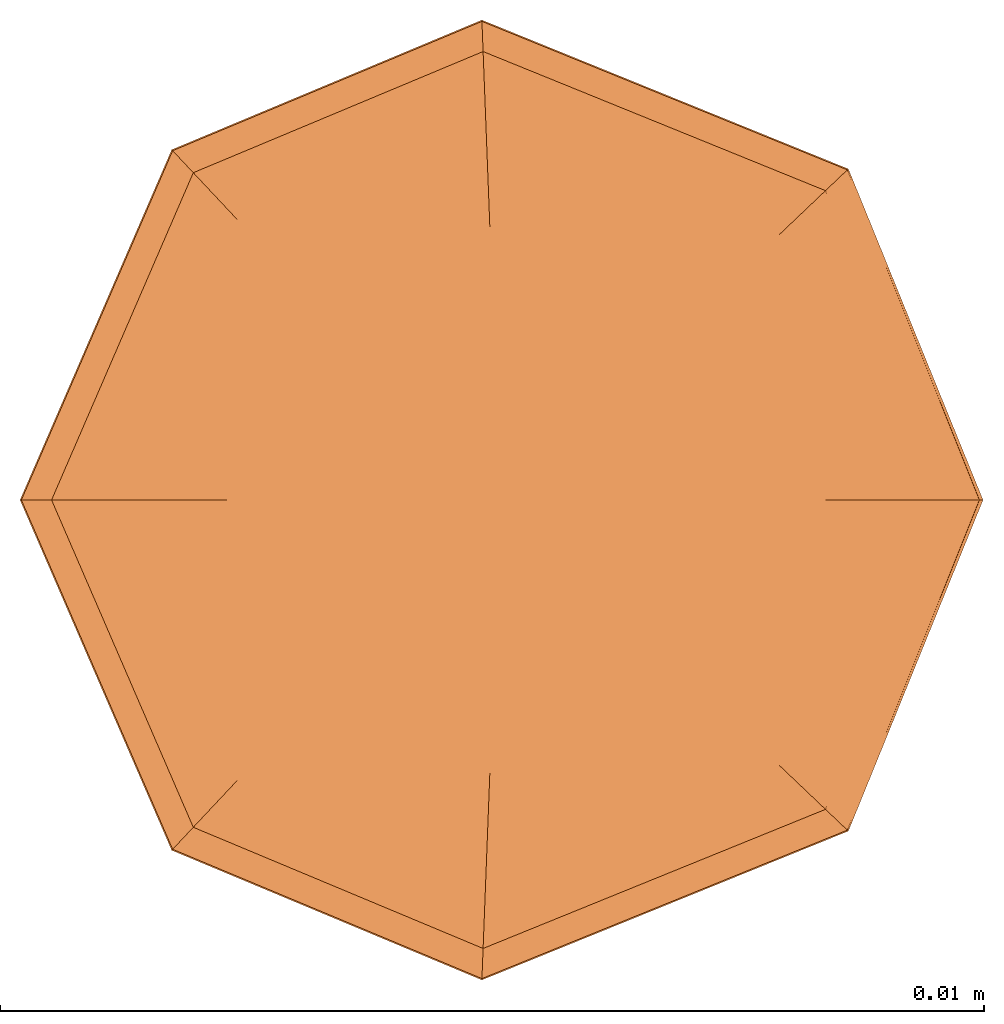
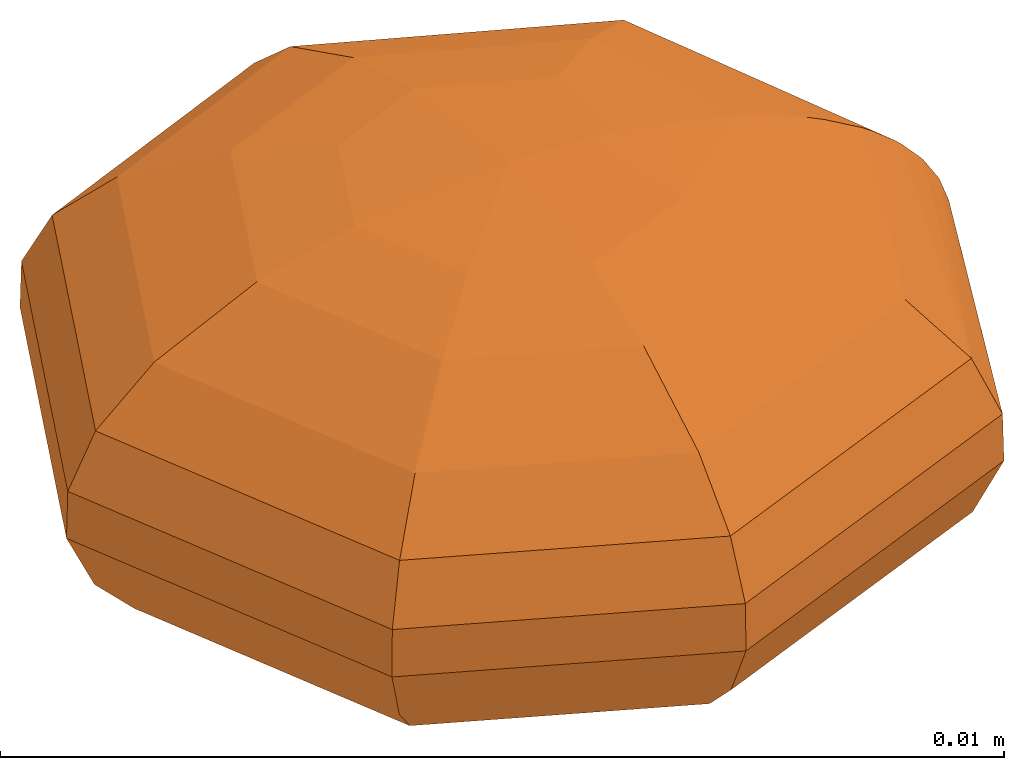
# One storey: 1 proxy.
"""IFC2X3 building model written with IfcOpenShell, lengths in metres."""

from ifc_helpers import new_model, entity, si_unit, converted_unit, direction, origin_with_axes, place, context, project, spatial, faceted_brep, element, save


model = new_model("IFC2X3")

# Units and contexts
model_context = context("Model", 3, precision=1e-05, world=origin_with_axes(), true_north=direction((0.0, 1.0, 0.0)))
ifc_project = project(units=[si_unit("LENGTHUNIT", "METRE"), si_unit("AREAUNIT", "SQUARE_METRE"), si_unit("VOLUMEUNIT", "CUBIC_METRE"), converted_unit("PLANEANGLEUNIT", "DEGREE", entity("IfcPlaneAngleMeasure", 0.017453292519943295), si_unit("PLANEANGLEUNIT", "RADIAN"), dimensions=[0, 0, 0, 0, 0, 0, 0])], contexts=[model_context])

# Site, building, storey
site = spatial("IfcSite", under=ifc_project, CompositionType="ELEMENT")
building = spatial("IfcBuilding", under=site, Name="Default Building", CompositionType="ELEMENT")
storey = spatial("IfcBuildingStorey", under=building, Name="Default Storey", CompositionType="ELEMENT")

# Proxy
proxy_placement = place(None, origin_with_axes())
element("IfcBuildingElementProxy", 1, at=proxy_placement, inside=storey, CompositionType="ELEMENT", context=model_context, shape_type="Brep", body=[
    faceted_brep([(-0.000152662271453074, 0.00396628215833403, 0.000247638885958941), (0.00288400588105378, 0.00274386681545339, -0.000196026131613179), (-0.00015310540430296, 0.0039777950874916, -0.000196026131613179), (0.0038979625190392, -9.55000817164605e-19, -0.000448856380194588), (0.00270157264392012, 0.00257029833950289, -0.000723718124612603), (-0.00254468377132875, 0.00271232097300763, 0.000736189419123744), (-0.000143044354009601, 0.00371640133320756, 0.000736189419123744), (-0.00271578146058632, 0.0028946901366087, 0.000247638885958941), (0.00287565870512634, 0.00273592524391204, 0.000247638885958941), (-0.00254468377132876, -0.00271232097300762, 0.000736189419123744), (-0.00396921905778001, 3.63396005958287e-18, 0.000247638885958941), (-0.00271578146058633, -0.00289469013660869, 0.000247638885958941), (-0.00371915320424972, 3.45968135853141e-18, 0.000736189419123744), (-0.00176506971101033, 1.69896230798885e-18, -0.00179475129999075), (-0.00120767927595444, 0.00128723807089298, -0.00179475129999075), (0.0, 0.0, -0.002), (-0.000129617050998011, -0.0033675497678369, -0.00107735880527708), (-0.0019942564412805, -0.00212563291053497, -0.00136972862057251), (-0.000112103172734707, -0.00291252586299263, -0.00136972862057251), (-0.00230581911775401, -0.00245772053231605, -0.00107735880527708), (-0.00272366456075797, 0.00290309255508159, -0.000196026131613179), (-0.00398074051187704, 3.63778251990386e-18, -0.000196026131613179), (-0.000143420432884163, 0.00372617214898348, -0.000723718124612603), (-0.00255137401657096, 0.00271945195434584, -0.000723718124612603), (-0.000152662271453083, -0.00396628215833403, 0.000247638885958941), (-0.00272366456075798, -0.00290309255508159, -0.000196026131613179), (-0.000153105404302969, -0.0039777950874916, -0.000196026131613179), (-0.000947249785860373, 0.00100965215788856, 0.00187638751083421), (0.0, 0.0, 0.002), (-5.32477690276527e-05, 0.00138341762018384, 0.00187638751083421), (-0.0019942564412805, 0.00212563291053497, -0.00136972862057251), (-0.0001121031727347, 0.00291252586299263, -0.00136972862057251), (-6.78872965773188e-05, 0.00176376370290624, -0.00179475129999075), (-8.71058835748227e-05, 0.00226307723984665, 0.00164855193818202), (-0.00154956782359426, 0.00165164935399334, 0.00164855193818202), (-6.7887296577323e-05, -0.00176376370290624, -0.00179475129999075), (-0.00120767927595444, -0.00128723807089297, -0.00179475129999075), (-0.00291468249110227, 2.76340206212976e-18, -0.00136972862057251), (0.00288400588105377, -0.00274386681545339, -0.000196026131613179), (0.00397541174692305, -9.73975877996147e-19, -0.000221416712572831), (0.00127877499471157, 0.0012166370032292, -0.00179475129999075), (0.00176506971101033, -4.32442079197532e-19, -0.00179475129999075), (0.00398074051187704, -9.75281425409875e-19, -0.00019602613161318), (0.004, -9.8e-19, -4.9e-19), (0.00399968870455559, -9.79923732616119e-19, 2.4951285790703e-05), (0.00100301409821479, 0.000954275827800281, 0.00187638751083421), (0.00203456677252254, -4.98468859268023e-19, 0.001721956594121), (0.00164079041917477, 0.00156106144299626, 0.00164855193818202), (0.00138444199471901, -3.39188288706157e-19, 0.00187638751083421), (0.00101768288308343, -2.49332306355439e-19, 0.00193418726791636), (0.000683750669828254, -1.67518914107922e-19, 0.00197056368975412), (-0.000143420432884172, -0.00372617214898348, -0.000723718124612603), (0.00270157264392011, -0.00257029833950289, -0.000723718124612603), (-0.00372893125498833, 3.46745470559538e-18, -0.000723718124612603), (-0.00255137401657097, -0.00271945195434584, -0.000723718124612603), (0.00244156200145224, 0.0023229220847528, -0.00107735880527708), (-0.000129617050998003, 0.0033675497678369, -0.00107735880527708), (-0.00226475297294545, 2.16719591337292e-18, 0.00164855193818202), (-0.00218281415605064, 0.00232661232108326, 0.00120646150658946), (-0.002305819117754, 0.00245772053231605, -0.00107735880527708), (-0.00319026684345864, 3.009695545214e-18, 0.00120646150658946), (-0.00337004332594816, 3.16709775165534e-18, -0.00107735880527708), (0.00211165772314552, -0.00200904845243165, -0.00136972862057251), (0.00291468249110227, -7.14097210320057e-19, -0.00136972862057251), (0.00211165772314553, 0.00200904845243165, -0.00136972862057251), (0.00127877499471157, -0.0012166370032292, -0.00179475129999075), (-0.00218281415605065, -0.00232661232108326, 0.00120646150658946), (0.00231131577434249, 0.00219900475755446, 0.00120646150658946), (0.00328097424216654, -8.03838689330801e-19, 0.00114402884822015), (0.00348904167641087, -8.54815210720663e-19, 0.000978083352821735), (0.00319026684345864, -7.81615376647366e-19, 0.00120646150658946), (0.00284828076493727, -6.97828787409631e-19, 0.00140421656841888), (-0.00014304435400961, -0.00371640133320756, 0.000736189419123744), (0.00269532727926956, -6.60355183421041e-19, 0.00147776950652202), (0.00397092100783666, -9.72875646919982e-19, 0.000240720974118096), (-0.000122702570902252, 0.00318790630533043, 0.00120646150658946), (0.00269448854593603, 0.00256355847066154, 0.000736189419123744), (0.00396921905778001, -9.72458669156103e-19, 0.000247638885958942), (0.0038851186710027, -9.51854074395661e-19, 0.000475881527332756), (0.00387904835662534, -9.50366847373208e-19, 0.00048810445781673), (0.00287565870512633, -0.00273592524391205, 0.000247638885958941), (0.00337004332594816, -8.256606148573e-19, -0.00107735880527708), (-0.00138444199471901, 1.33799329944939e-18, 0.00187638751083421), (-0.00154956782359426, -0.00165164935399334, 0.00164855193818202), (0.00244156200145224, -0.0023229220847528, -0.00107735880527708), (-0.00012270257090226, -0.00318790630533043, 0.00120646150658946), (0.00269448854593602, -0.00256355847066155, 0.000736189419123744), (0.0037432456056233, -9.17095173377708e-19, 0.000705002187227434), (0.00371915320424972, -9.11192535041182e-19, 0.000736189419123744), (0.00354163030753432, -8.67699425345909e-19, 0.000929630943540814), (0.00372893125498833, -9.13588157472142e-19, -0.000723718124612603), (-0.000947249785860375, -0.00100965215788856, 0.00187638751083421), (-8.71058835748283e-05, -0.00226307723984665, 0.00164855193818202), (0.00231131577434248, -0.00219900475755446, 0.00120646150658946), (0.00226475297294545, -5.54864478371636e-19, 0.00164855193818202), (-5.32477690276558e-05, -0.00138341762018384, 0.00187638751083421), (0.00164079041917477, -0.00156106144299626, 0.00164855193818202), (0.00100301409821479, -0.000954275827800284, 0.00187638751083421)], [[[0, 1, 2]], [[1, 3, 4]], [[5, 6, 0]], [[5, 0, 7]], [[0, 8, 1]], [[9, 10, 11]], [[9, 12, 10]], [[13, 14, 15]], [[16, 17, 18]], [[16, 19, 17]], [[10, 20, 21]], [[20, 2, 22]], [[20, 22, 23]], [[24, 11, 25]], [[24, 25, 26]], [[27, 28, 29]], [[30, 31, 32]], [[27, 33, 34]], [[30, 32, 14]], [[27, 29, 33]], [[35, 36, 15]], [[17, 37, 13]], [[38, 3, 39]], [[10, 7, 20]], [[40, 41, 15]], [[38, 39, 42]], [[38, 42, 43]], [[38, 43, 44]], [[45, 46, 47]], [[17, 13, 36]], [[45, 48, 46]], [[45, 49, 48]], [[45, 50, 49]], [[38, 26, 51]], [[45, 28, 50]], [[38, 51, 52]], [[38, 52, 3]], [[25, 53, 54]], [[22, 55, 56]], [[22, 4, 55]], [[57, 34, 58]], [[59, 31, 30]], [[57, 58, 60]], [[59, 56, 31]], [[53, 59, 61]], [[53, 23, 59]], [[32, 40, 15]], [[25, 21, 53]], [[62, 18, 35]], [[62, 41, 63]], [[64, 63, 41]], [[62, 65, 41]], [[66, 60, 12]], [[64, 41, 40]], [[66, 12, 9]], [[67, 68, 69]], [[62, 35, 65]], [[67, 70, 68]], [[33, 47, 67]], [[67, 71, 70]], [[72, 9, 11]], [[67, 73, 71]], [[8, 44, 1]], [[8, 74, 44]], [[33, 67, 75]], [[67, 69, 76]], [[8, 77, 74]], [[6, 76, 8]], [[8, 78, 77]], [[8, 79, 78]], [[72, 11, 24]], [[80, 44, 74]], [[51, 19, 16]], [[80, 74, 77]], [[80, 77, 78]], [[80, 78, 79]], [[55, 81, 63]], [[51, 54, 19]], [[6, 8, 0]], [[58, 6, 5]], [[80, 24, 26]], [[80, 38, 44]], [[80, 26, 38]], [[2, 1, 4]], [[82, 28, 27]], [[82, 34, 57]], [[55, 63, 64]], [[58, 75, 6]], [[82, 27, 34]], [[19, 61, 37]], [[19, 37, 17]], [[12, 7, 10]], [[2, 4, 22]], [[83, 57, 60]], [[83, 60, 66]], [[14, 32, 15]], [[12, 5, 7]], [[84, 62, 63]], [[84, 63, 81]], [[7, 0, 2]], [[36, 13, 15]], [[84, 18, 62]], [[7, 2, 20]], [[84, 16, 18]], [[85, 66, 9]], [[21, 20, 23]], [[85, 9, 72]], [[86, 24, 80]], [[86, 79, 87]], [[86, 87, 88]], [[86, 88, 89]], [[31, 40, 32]], [[86, 89, 69]], [[37, 14, 13]], [[37, 30, 14]], [[31, 64, 40]], [[86, 80, 79]], [[11, 21, 25]], [[4, 90, 81]], [[86, 72, 24]], [[21, 23, 53]], [[4, 3, 90]], [[11, 10, 21]], [[65, 15, 41]], [[29, 47, 33]], [[91, 28, 82]], [[65, 35, 15]], [[91, 82, 57]], [[91, 57, 83]], [[29, 28, 45]], [[23, 22, 56]], [[29, 45, 47]], [[92, 66, 85]], [[23, 56, 59]], [[18, 17, 36]], [[18, 36, 35]], [[4, 81, 55]], [[76, 87, 79]], [[92, 83, 66]], [[76, 88, 87]], [[76, 89, 88]], [[93, 69, 68]], [[26, 54, 51]], [[76, 69, 89]], [[93, 68, 70]], [[47, 94, 73]], [[93, 70, 71]], [[47, 46, 94]], [[93, 71, 73]], [[26, 25, 54]], [[56, 55, 64]], [[93, 86, 69]], [[47, 73, 67]], [[93, 85, 72]], [[93, 72, 86]], [[34, 33, 75]], [[95, 91, 83]], [[34, 75, 58]], [[76, 79, 8]], [[52, 81, 90]], [[95, 83, 92]], [[52, 90, 3]], [[56, 64, 31]], [[95, 28, 91]], [[54, 61, 19]], [[96, 85, 93]], [[52, 84, 81]], [[54, 53, 61]], [[52, 16, 84]], [[96, 73, 94]], [[52, 51, 16]], [[96, 94, 46]], [[60, 58, 5]], [[61, 59, 30]], [[96, 93, 73]], [[75, 76, 6]], [[1, 39, 3]], [[96, 92, 85]], [[61, 30, 37]], [[1, 42, 39]], [[97, 28, 95]], [[1, 43, 42]], [[97, 95, 92]], [[1, 44, 43]], [[97, 96, 46]], [[97, 46, 48]], [[97, 48, 49]], [[97, 49, 50]], [[75, 67, 76]], [[97, 50, 28]], [[97, 92, 96]], [[60, 5, 12]]]),
])

save(model, "model.ifc")
